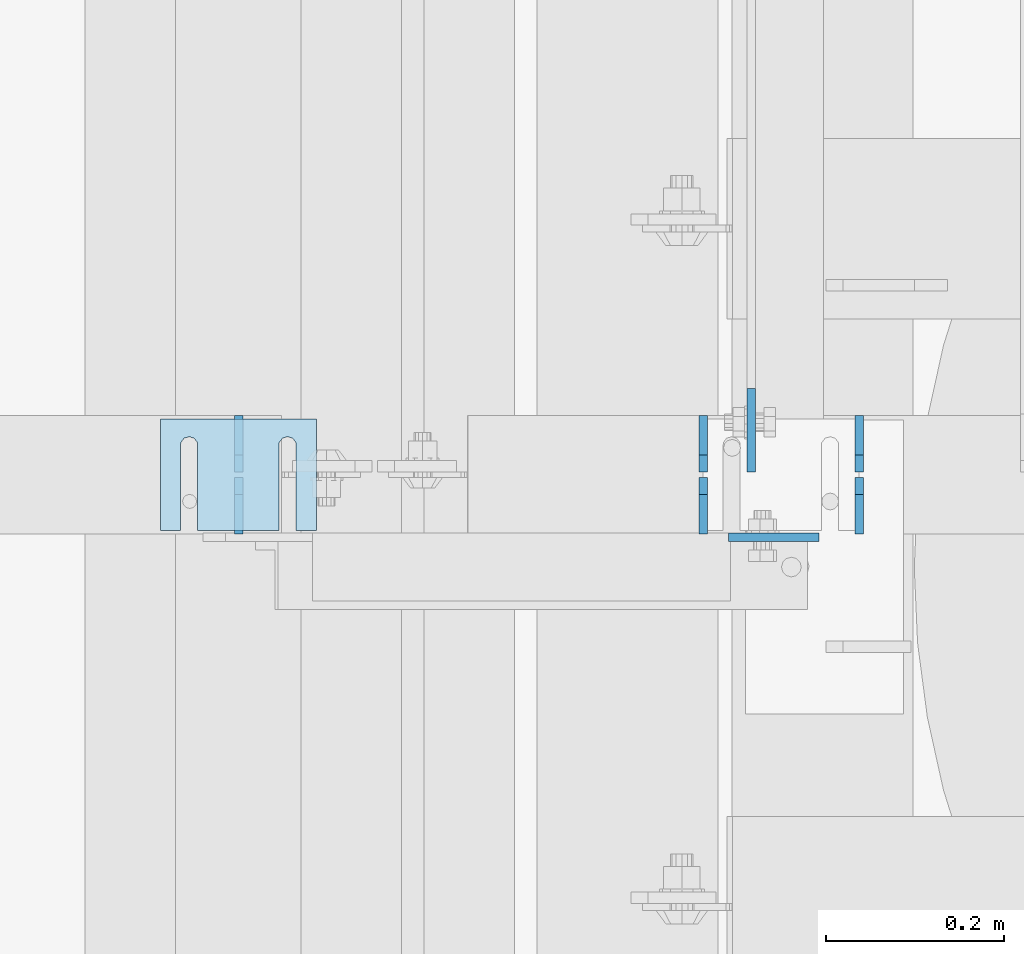
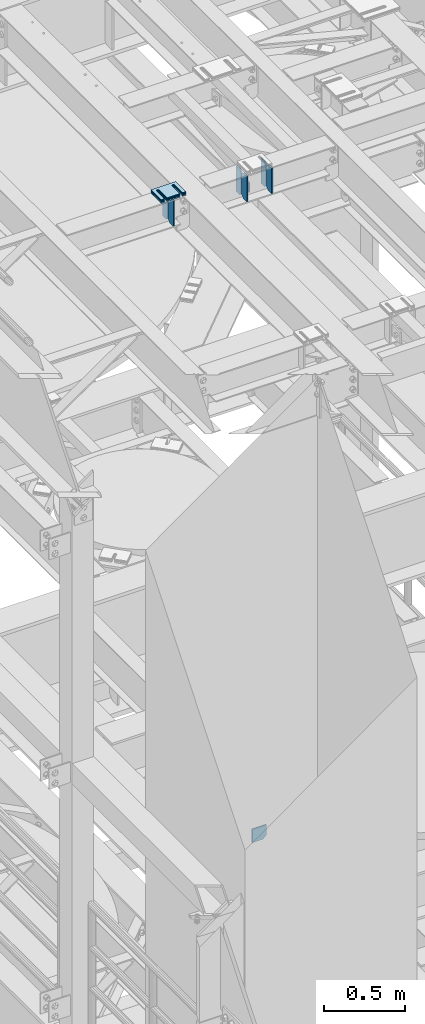
# One storey, part 1628 of 1876: 14 plates, 9 elements without a shape of their own.
"""IFC2X3 building model written with IfcOpenShell, lengths in millimetres."""

from ifc_helpers import new_model, si_unit, frame, origin_with_axes, place, context, subcontext, project, spatial, faceted_brep, material, type_object, element, aggregate, save


model = new_model("IFC2X3")

# Units and contexts
model_context = context("Model", 3, precision=1e-05, world=origin_with_axes())
body_context = subcontext(model_context, "Body", "Model", "MODEL_VIEW")
ifc_project = project(units=[si_unit("LENGTHUNIT", "METRE", prefix="MILLI"), si_unit("AREAUNIT", "SQUARE_METRE"), si_unit("VOLUMEUNIT", "CUBIC_METRE"), si_unit("MASSUNIT", "GRAM", prefix="KILO"), si_unit("TIMEUNIT", "SECOND"), si_unit("PLANEANGLEUNIT", "RADIAN"), si_unit("SOLIDANGLEUNIT", "STERADIAN"), si_unit("THERMODYNAMICTEMPERATUREUNIT", "DEGREE_CELSIUS"), si_unit("LUMINOUSINTENSITYUNIT", "LUMEN")], contexts=[model_context])

# Site, building, storey
site_placement = place(None, origin_with_axes())
site = spatial("IfcSite", under=ifc_project, at=site_placement, CompositionType="ELEMENT")
building_placement = place(site_placement, origin_with_axes())
building = spatial("IfcBuilding", under=site, at=building_placement, Name="Undefined", CompositionType="ELEMENT")
storey_placement = place(building_placement, origin_with_axes())
storey = spatial("IfcBuildingStorey", under=building, at=storey_placement, Name="Undefined", CompositionType="ELEMENT", Elevation=0.0)

# Assembly, plates
assembly_1_placement = place(storey_placement, origin_with_axes())
assembly_1 = element("IfcElementAssembly", 1, at=assembly_1_placement, inside=storey, Name="BEAM", AssemblyPlace="NOTDEFINED", PredefinedType="RIGID_FRAME")
ifc_material = material(Name="STEEL/A36")
plate_type_1 = type_object("IfcPlateType", PredefinedType="NOTDEFINED")
plate_1_placement = place(assembly_1_placement, frame((2343.14899226351, 5213.12356567383, 17784.7625), z_axis=(0.0, 0.0, 1.0), x_axis=(0.0, 1.0, 0.0)))
plate_1 = element("IfcPlate", 2, at=plate_1_placement, type_object=plate_type_1, material=ifc_material, Name="PLATE", context=body_context, shape_type="Brep", body=[
    faceted_brep([(0.0, -4.76249999999982, 0.0), (0.0, -4.76249999999982, 190.5), (0.0, 4.76249999999982, 190.5), (0.0, 4.76249999999982, 0.0), (44.4500007629395, -4.76249999999982, 190.5), (44.4500007629395, 4.76249999999982, 190.5), (63.5, -4.76249999999982, 171.450000762939), (63.5, 4.76249999999982, 171.450000762939), (63.5, -4.76249999999982, 19.0499992370605), (63.5, 4.76249999999982, 19.0499992370605), (44.4500007629395, -4.76249999999982, 0.0), (44.4500007629395, 4.76249999999982, 0.0)], [[[0, 1, 2, 3]], [[1, 4, 5, 2]], [[4, 6, 7, 5]], [[6, 8, 9, 7]], [[8, 10, 11, 9]], [[10, 0, 3, 11]], [[5, 7, 9, 11, 3, 2]], [[10, 8, 6, 4, 1, 0]]]),
])
plate_2_placement = place(assembly_1_placement, frame((2343.14899226351, 5282.97356567383, 17784.7625), z_axis=(0.0, 0.0, 1.0), x_axis=(0.0, 1.0, 0.0)))
plate_2 = element("IfcPlate", 3, at=plate_2_placement, type_object=plate_type_1, material=ifc_material, Name="PLATE", context=body_context, shape_type="Brep", body=[
    faceted_brep([(0.0, -4.76249999999982, 19.0499992370605), (0.0, -4.76249999999982, 171.450000762939), (0.0, 4.76249999999982, 171.450000762939), (0.0, 4.76249999999982, 19.0499992370605), (19.0499992370605, -4.76249999999982, 190.5), (19.0499992370605, 4.76249999999982, 190.5), (63.5, -4.76249999999982, 190.5), (63.5, 4.76249999999982, 190.5), (63.5, -4.76249999999982, 0.0), (63.5, 4.76249999999982, 0.0), (19.0499992370605, -4.76249999999982, 0.0), (19.0499992370605, 4.76249999999982, 0.0)], [[[0, 1, 2, 3]], [[1, 4, 5, 2]], [[4, 6, 7, 5]], [[6, 8, 9, 7]], [[8, 10, 11, 9]], [[10, 0, 3, 11]], [[5, 7, 9, 11, 3, 2]], [[10, 8, 6, 4, 1, 0]]]),
])
plate_3_placement = place(assembly_1_placement, frame((2167.75127412194, 5213.12356567383, 17784.7625), z_axis=(0.0, 0.0, 1.0), x_axis=(0.0, 1.0, 0.0)))
plate_3 = element("IfcPlate", 4, at=plate_3_placement, type_object=plate_type_1, material=ifc_material, Name="PLATE", context=body_context, shape_type="Brep", body=[
    faceted_brep([(0.0, -4.76249999999982, 0.0), (0.0, -4.76249999999982, 190.5), (0.0, 4.76249999999982, 190.5), (0.0, 4.76249999999982, 0.0), (44.4500007629395, -4.76249999999982, 190.5), (44.4500007629395, 4.76249999999982, 190.5), (63.5, -4.76249999999982, 171.450000762939), (63.5, 4.76249999999982, 171.450000762939), (63.5, -4.76249999999982, 19.0499992370605), (63.5, 4.76249999999982, 19.0499992370605), (44.4500007629395, -4.76249999999982, 0.0), (44.4500007629395, 4.76249999999982, 0.0)], [[[0, 1, 2, 3]], [[1, 4, 5, 2]], [[4, 6, 7, 5]], [[6, 8, 9, 7]], [[8, 10, 11, 9]], [[10, 0, 3, 11]], [[5, 7, 9, 11, 3, 2]], [[10, 8, 6, 4, 1, 0]]]),
])
plate_4_placement = place(assembly_1_placement, frame((2167.75127412194, 5282.97356567383, 17784.7625), z_axis=(0.0, 0.0, 1.0), x_axis=(0.0, 1.0, 0.0)))
plate_4 = element("IfcPlate", 5, at=plate_4_placement, type_object=plate_type_1, material=ifc_material, Name="PLATE", context=body_context, shape_type="Brep", body=[
    faceted_brep([(0.0, -4.76249999999982, 19.0499992370605), (0.0, -4.76249999999982, 171.450000762939), (0.0, 4.76249999999982, 171.450000762939), (0.0, 4.76249999999982, 19.0499992370605), (19.0499992370605, -4.76249999999982, 190.5), (19.0499992370605, 4.76249999999982, 190.5), (63.5, -4.76249999999982, 190.5), (63.5, 4.76249999999982, 190.5), (63.5, -4.76249999999982, 0.0), (63.5, 4.76249999999982, 0.0), (19.0499992370605, -4.76249999999982, 0.0), (19.0499992370605, 4.76249999999982, 0.0)], [[[0, 1, 2, 3]], [[1, 4, 5, 2]], [[4, 6, 7, 5]], [[6, 8, 9, 7]], [[8, 10, 11, 9]], [[10, 0, 3, 11]], [[5, 7, 9, 11, 3, 2]], [[10, 8, 6, 4, 1, 0]]]),
])

assembly_2_placement = place(storey_placement, origin_with_axes())
assembly_2 = element("IfcElementAssembly", 6, at=assembly_2_placement, inside=storey, Name="BEAM", AssemblyPlace="NOTDEFINED", PredefinedType="RIGID_FRAME")
plate_5_placement = place(assembly_2_placement, frame((1646.20416884927, 5213.12356567383, 17784.7625), z_axis=(0.0, 0.0, 1.0), x_axis=(0.0, 1.0, 0.0)))
plate_5 = element("IfcPlate", 7, at=plate_5_placement, type_object=plate_type_1, material=ifc_material, Name="PLATE", context=body_context, shape_type="Brep", body=[
    faceted_brep([(0.0, -4.76249999999982, 0.0), (0.0, -4.76249999999982, 190.5), (0.0, 4.76249999999982, 190.5), (0.0, 4.76249999999982, 0.0), (44.4500007629395, -4.76249999999982, 190.5), (44.4500007629395, 4.76249999999982, 190.5), (63.5, -4.76249999999982, 171.450000762939), (63.5, 4.76249999999982, 171.450000762939), (63.5, -4.76249999999982, 19.0499992370605), (63.5, 4.76249999999982, 19.0499992370605), (44.4500007629395, -4.76249999999982, 0.0), (44.4500007629395, 4.76249999999982, 0.0)], [[[0, 1, 2, 3]], [[1, 4, 5, 2]], [[4, 6, 7, 5]], [[6, 8, 9, 7]], [[8, 10, 11, 9]], [[10, 0, 3, 11]], [[5, 7, 9, 11, 3, 2]], [[10, 8, 6, 4, 1, 0]]]),
])
plate_6_placement = place(assembly_2_placement, frame((1646.20416884927, 5282.97356567383, 17784.7625), z_axis=(0.0, 0.0, 1.0), x_axis=(0.0, 1.0, 0.0)))
plate_6 = element("IfcPlate", 8, at=plate_6_placement, type_object=plate_type_1, material=ifc_material, Name="PLATE", context=body_context, shape_type="Brep", body=[
    faceted_brep([(0.0, -4.76249999999982, 19.0499992370605), (0.0, -4.76249999999982, 171.450000762939), (0.0, 4.76249999999982, 171.450000762939), (0.0, 4.76249999999982, 19.0499992370605), (19.0499992370605, -4.76249999999982, 190.5), (19.0499992370605, 4.76249999999982, 190.5), (63.5, -4.76249999999982, 190.5), (63.5, 4.76249999999982, 190.5), (63.5, -4.76249999999982, 0.0), (63.5, 4.76249999999982, 0.0), (19.0499992370605, -4.76249999999982, 0.0), (19.0499992370605, 4.76249999999982, 0.0)], [[[0, 1, 2, 3]], [[1, 4, 5, 2]], [[4, 6, 7, 5]], [[6, 8, 9, 7]], [[8, 10, 11, 9]], [[10, 0, 3, 11]], [[5, 7, 9, 11, 3, 2]], [[10, 8, 6, 4, 1, 0]]]),
])
aggregate(assembly_2, [plate_5, plate_6])

# Plate
plate_type_2 = type_object("IfcPlateType", PredefinedType="NOTDEFINED")
plate_7_placement = place(assembly_1_placement, frame((2222.11263366315, 5282.97350482595, 17866.0340203351), z_axis=(2.79999999293068e-08, 0.999999999998546, 1.70500000240281e-06), x_axis=(0.0, 1.70500000384316e-06, -0.999999999998546)))
plate_7 = element("IfcPlate", 9, at=plate_7_placement, type_object=plate_type_2, material=ifc_material, Name="PLATE", context=body_context, shape_type="Brep", body=[
    faceted_brep([(0.0, -4.76249999999982, 0.0), (0.000160036299348576, -4.76250000001437, 93.8535079955736), (0.000160036299348576, 4.76249999998527, 93.8535079955709), (0.0, 4.76249999999982, 0.0), (81.2716827393124, -4.76250000001482, 93.8533706664484), (81.2716827393124, 4.76249999998527, 93.8533706664448), (81.2715442022745, -4.76250000000164, 12.6999998092087), (81.2715442022745, 4.762499999998, 12.699999809206), (68.5715227128021, -4.76249999999982, -2.81943357549608e-11), (68.5715227128021, 4.76249999999982, -3.09228198602796e-11)], [[[0, 1, 2, 3]], [[1, 4, 5, 2]], [[4, 6, 7, 5]], [[6, 8, 9, 7]], [[8, 0, 3, 9]], [[5, 7, 9, 3, 2]], [[8, 6, 4, 1, 0]]]),
])

aggregate(assembly_1, [plate_1, plate_2, plate_3, plate_4, plate_7])

# Assembly, plate
assembly_3_placement = place(storey_placement, origin_with_axes())
assembly_3 = element("IfcElementAssembly", 10, at=assembly_3_placement, inside=storey, Name="BEAM", AssemblyPlace="NOTDEFINED", PredefinedType="RIGID_FRAME")
plate_type_3 = type_object("IfcPlateType", PredefinedType="NOTDEFINED")
plate_8_placement = place(assembly_3_placement, frame((2196.38446405378, 5209.4243484497, 13076.6976143139), z_axis=(1.0, 0.0, 0.0), x_axis=(0.0, 0.0, -1.0)))
plate_8 = element("IfcPlate", 11, at=plate_8_placement, type_object=plate_type_3, material=ifc_material, Name="PLATE", context=body_context, shape_type="Brep", body=[
    faceted_brep([(0.0, -4.76249999999982, 0.0), (0.0, -4.76249999999982, 101.521789550781), (0.0, 4.76249999999982, 101.521789550781), (0.0, 4.76249999999982, 0.0), (75.0726184844971, -4.76249999999982, 101.521789550781), (75.0726184844971, 4.76249999999982, 101.521789550781), (100.472618103027, -4.76249999999982, 76.121789932251), (100.472618103027, 4.76249999999982, 76.121789932251), (100.472618103027, -4.76249999999982, 0.0), (100.472618103027, 4.76249999999982, 0.0)], [[[0, 1, 2, 3]], [[1, 4, 5, 2]], [[4, 6, 7, 5]], [[6, 8, 9, 7]], [[8, 0, 3, 9]], [[5, 7, 9, 3, 2]], [[8, 6, 4, 1, 0]]]),
])
aggregate(assembly_3, [plate_8])

assembly_4_placement = place(storey_placement, origin_with_axes())
assembly_4 = element("IfcElementAssembly", 12, at=assembly_4_placement, inside=storey, Name="SHIM PLATE", AssemblyPlace="NOTDEFINED", PredefinedType="RIGID_FRAME")
plate_type_4 = type_object("IfcPlateType", PredefinedType="NOTDEFINED")
plate_9_placement = place(assembly_4_placement, frame((1733.54893551387, 5342.49779911298, 18009.3925), z_axis=(0.0, -1.0, 0.0), x_axis=(-1.0, 0.0, 0.0)))
plate_9 = element("IfcPlate", 13, at=plate_9_placement, type_object=plate_type_4, material=ifc_material, Name="SHIM PLATE", context=body_context, shape_type="Brep", body=[
    faceted_brep([(133.797984932592, -0.793499999999767, 125.39846801759), (133.799788185712, -0.793499999999767, 32.6385373098888), (133.799788185712, 0.793499999999767, 32.6385373098888), (133.797984932592, 0.793499999999767, 125.39846801759), (133.95251601168, -0.793499999999767, 26.6039999741197), (133.95251601168, 0.793499999999767, 26.6039999741197), (137.574395327988, -0.793499999999767, 21.7748223149583), (137.574395327988, 0.793499999999767, 21.7748223149583), (143.324785467194, -0.793499999999767, 19.9385271609622), (143.324785467194, 0.793499999999767, 19.9385271609622), (149.075176282759, -0.793499999999767, 21.7748201969102), (149.075176282759, 0.793499999999767, 21.7748201969102), (152.697057377795, -0.793499999999767, 26.6039965220207), (152.697057377795, 0.793499999999767, 26.6039965220207), (152.84978742646, -0.793499999999767, 32.6385338015343), (152.84978742646, 0.793499999999767, 32.6385338015343), (152.847984173361, -0.793499999999767, 125.398468017593), (152.847984173361, 0.793499999999767, 125.398468017593), (42.2236708188493, -0.793499999999767, 125.398468017582), (42.2236708188493, 0.793499999999767, 125.398468017582), (42.2254740719682, 0.793499999999767, 32.6385328059155), (42.2254740719682, -0.793499999999767, 32.6385328059155), (42.0727440233031, 0.793499999999767, 26.6039955264014), (42.0727440233031, -0.793499999999767, 26.6039955264014), (38.4508629282668, 0.793499999999767, 21.7748192012914), (38.4508629282668, -0.793499999999767, 21.7748192012914), (32.7004721127014, 0.793499999999767, 19.9385261653433), (32.7004721127014, -0.793499999999767, 19.9385261653433), (26.9500819734958, 0.793499999999767, 21.7748213193395), (26.9500819734958, -0.793499999999767, 21.7748213193395), (23.3282026571874, 0.793499999999767, 26.6039989785008), (23.3282026571874, -0.793499999999767, 26.6039989785008), (23.1754748312196, 0.793499999999767, 32.6385363142699), (23.1754748312196, -0.793499999999767, 32.6385363142699), (23.1736715780803, -0.793499999999767, 125.39846801758), (23.1736715780803, 0.793499999999767, 125.39846801758), (1.96488858819066e-05, 0.793499999999767, 125.398468017578), (1.96488858819066e-05, -0.793499999999767, 125.398468017578), (9.09494701772928e-13, -0.793499999999767, 0.0), (9.09494701772928e-13, 0.793499999999767, 0.0), (175.397720336914, -0.793499999999767, 7.27595761418343e-12), (175.397720336914, 0.793499999999767, 7.27595761418343e-12), (175.397735595691, -0.793499999999767, 125.398468017594), (175.397735595691, 0.793499999999767, 125.398468017594)], [[[0, 1, 2, 3]], [[4, 5, 2, 1]], [[6, 7, 5, 4]], [[8, 9, 7, 6]], [[10, 11, 9, 8]], [[12, 13, 11, 10]], [[14, 15, 13, 12]], [[16, 17, 15, 14]], [[18, 19, 20, 21]], [[21, 20, 22, 23]], [[23, 22, 24, 25]], [[25, 24, 26, 27]], [[27, 26, 28, 29]], [[29, 28, 30, 31]], [[31, 30, 32, 33]], [[34, 33, 32, 35]], [[36, 37, 34, 35]], [[38, 37, 36, 39]], [[40, 38, 39, 41]], [[42, 40, 41, 43]], [[12, 10, 8, 6, 4, 1, 0, 18, 21, 23, 25, 27, 29, 31, 33, 34, 37, 38, 40, 42, 16, 14]], [[19, 18, 0, 3]], [[43, 41, 39, 36, 35, 32, 30, 28, 26, 24, 22, 20, 19, 3, 2, 5, 7, 9, 11, 13, 15, 17]], [[42, 43, 17, 16]]]),
])
aggregate(assembly_4, [plate_9])

assembly_5_placement = place(storey_placement, origin_with_axes())
assembly_5 = element("IfcElementAssembly", 14, at=assembly_5_placement, inside=storey, Name="SHIM PLATE", AssemblyPlace="NOTDEFINED", PredefinedType="RIGID_FRAME")
plate_type_5 = type_object("IfcPlateType", PredefinedType="NOTDEFINED")
plate_10_placement = place(assembly_5_placement, frame((1733.54893551387, 5342.49779911306, 18007.0115), z_axis=(0.0, -1.0, 0.0), x_axis=(-1.0, 0.0, 0.0)))
plate_10 = element("IfcPlate", 15, at=plate_10_placement, type_object=plate_type_5, material=ifc_material, Name="SHIM PLATE", context=body_context, shape_type="Brep", body=[
    faceted_brep([(133.797984932592, -1.58750000000146, 125.39846801759), (133.799788185712, -1.58750000000146, 32.6385373098888), (133.799788185712, 1.58750000000146, 32.6385373098888), (133.797984932592, 1.58750000000146, 125.39846801759), (133.95251601168, -1.58750000000146, 26.6039999741197), (133.95251601168, 1.58750000000146, 26.6039999741197), (137.574395327988, -1.58750000000146, 21.7748223149583), (137.574395327988, 1.58750000000146, 21.7748223149583), (143.324785467194, -1.58750000000146, 19.9385271609622), (143.324785467194, 1.58750000000146, 19.9385271609622), (149.075176282759, -1.58750000000146, 21.7748201969102), (149.075176282759, 1.58750000000146, 21.7748201969102), (152.697057377795, -1.58750000000146, 26.6039965220207), (152.697057377795, 1.58750000000146, 26.6039965220207), (152.84978742646, -1.58750000000146, 32.6385338015343), (152.84978742646, 1.58750000000146, 32.6385338015343), (152.847984173361, -1.58750000000146, 125.398468017593), (152.847984173361, 1.58750000000146, 125.398468017593), (42.2236708188493, -1.58750000000146, 125.398468017582), (42.2236708188493, 1.58750000000146, 125.398468017582), (42.2254740719682, 1.58750000000146, 32.6385328059155), (42.2254740719682, -1.58750000000146, 32.6385328059155), (42.0727440233031, 1.58750000000146, 26.6039955264014), (42.0727440233031, -1.58750000000146, 26.6039955264014), (38.4508629282668, 1.58750000000146, 21.7748192012914), (38.4508629282668, -1.58750000000146, 21.7748192012914), (32.7004721127014, 1.58750000000146, 19.9385261653433), (32.7004721127014, -1.58750000000146, 19.9385261653433), (26.9500819734958, 1.58750000000146, 21.7748213193395), (26.9500819734958, -1.58750000000146, 21.7748213193395), (23.3282026571874, 1.58750000000146, 26.6039989785008), (23.3282026571874, -1.58750000000146, 26.6039989785008), (23.1754748312196, 1.58750000000146, 32.6385363142699), (23.1754748312196, -1.58750000000146, 32.6385363142699), (23.1736715780803, -1.58750000000146, 125.39846801758), (23.1736715780803, 1.58750000000146, 125.39846801758), (1.96491696442536e-05, 1.58750000000146, 125.398468017578), (1.96491696442536e-05, -1.58750000000146, 125.398468017578), (9.09494701772928e-13, -1.58750000000146, 4.54747350886464e-13), (9.09494701772928e-13, 1.58750000000146, 4.54747350886464e-13), (175.397720336914, -1.58750000000146, 7.27595761418343e-12), (175.397720336914, 1.58750000000146, 7.27595761418343e-12), (175.397735595691, -1.58750000000146, 125.398468017594), (175.397735595691, 1.58750000000146, 125.398468017594)], [[[0, 1, 2, 3]], [[4, 5, 2, 1]], [[6, 7, 5, 4]], [[8, 9, 7, 6]], [[10, 11, 9, 8]], [[12, 13, 11, 10]], [[14, 15, 13, 12]], [[16, 17, 15, 14]], [[18, 19, 20, 21]], [[21, 20, 22, 23]], [[23, 22, 24, 25]], [[25, 24, 26, 27]], [[27, 26, 28, 29]], [[29, 28, 30, 31]], [[31, 30, 32, 33]], [[34, 33, 32, 35]], [[36, 37, 34, 35]], [[38, 37, 36, 39]], [[40, 38, 39, 41]], [[42, 40, 41, 43]], [[12, 10, 8, 6, 4, 1, 0, 18, 21, 23, 25, 27, 29, 31, 33, 34, 37, 38, 40, 42, 16, 14]], [[19, 18, 0, 3]], [[43, 41, 39, 36, 35, 32, 30, 28, 26, 24, 22, 20, 19, 3, 2, 5, 7, 9, 11, 13, 15, 17]], [[42, 43, 17, 16]]]),
])
aggregate(assembly_5, [plate_10])

assembly_6_placement = place(storey_placement, origin_with_axes())
assembly_6 = element("IfcElementAssembly", 16, at=assembly_6_placement, inside=storey, Name="SHIM PLATE", AssemblyPlace="NOTDEFINED", PredefinedType="RIGID_FRAME")
plate_11_placement = place(assembly_6_placement, frame((1733.54893551387, 5342.49779911314, 18003.8365), z_axis=(0.0, -1.0, 0.0), x_axis=(-1.0, 0.0, 0.0)))
plate_11 = element("IfcPlate", 17, at=plate_11_placement, type_object=plate_type_5, material=ifc_material, Name="SHIM PLATE", context=body_context, shape_type="Brep", body=[
    faceted_brep([(133.797984932592, -1.58750000000146, 125.39846801759), (133.799788185712, -1.58750000000146, 32.6385373098888), (133.799788185712, 1.58750000000146, 32.6385373098888), (133.797984932592, 1.58750000000146, 125.39846801759), (133.95251601168, -1.58750000000146, 26.6039999741197), (133.95251601168, 1.58750000000146, 26.6039999741197), (137.574395327988, -1.58750000000146, 21.7748223149583), (137.574395327988, 1.58750000000146, 21.7748223149583), (143.324785467194, -1.58750000000146, 19.9385271609622), (143.324785467194, 1.58750000000146, 19.9385271609622), (149.075176282759, -1.58750000000146, 21.7748201969102), (149.075176282759, 1.58750000000146, 21.7748201969102), (152.697057377795, -1.58750000000146, 26.6039965220207), (152.697057377795, 1.58750000000146, 26.6039965220207), (152.84978742646, -1.58750000000146, 32.6385338015343), (152.84978742646, 1.58750000000146, 32.6385338015343), (152.847984173361, -1.58750000000146, 125.398468017593), (152.847984173361, 1.58750000000146, 125.398468017593), (42.2236708188493, -1.58750000000146, 125.398468017582), (42.2236708188493, 1.58750000000146, 125.398468017582), (42.2254740719682, 1.58750000000146, 32.6385328059155), (42.2254740719682, -1.58750000000146, 32.6385328059155), (42.0727440233031, 1.58750000000146, 26.6039955264014), (42.0727440233031, -1.58750000000146, 26.6039955264014), (38.4508629282668, 1.58750000000146, 21.7748192012914), (38.4508629282668, -1.58750000000146, 21.7748192012914), (32.7004721127014, 1.58750000000146, 19.9385261653433), (32.7004721127014, -1.58750000000146, 19.9385261653433), (26.9500819734958, 1.58750000000146, 21.7748213193395), (26.9500819734958, -1.58750000000146, 21.7748213193395), (23.3282026571874, 1.58750000000146, 26.6039989785008), (23.3282026571874, -1.58750000000146, 26.6039989785008), (23.1754748312196, 1.58750000000146, 32.6385363142699), (23.1754748312196, -1.58750000000146, 32.6385363142699), (23.1736715780803, -1.58750000000146, 125.39846801758), (23.1736715780803, 1.58750000000146, 125.39846801758), (1.96491696442536e-05, 1.58750000000146, 125.398468017578), (1.96491696442536e-05, -1.58750000000146, 125.398468017578), (9.09494701772928e-13, -1.58750000000146, 4.54747350886464e-13), (9.09494701772928e-13, 1.58750000000146, 4.54747350886464e-13), (175.397720336914, -1.58750000000146, 7.27595761418343e-12), (175.397720336914, 1.58750000000146, 7.27595761418343e-12), (175.397735595691, -1.58750000000146, 125.398468017594), (175.397735595691, 1.58750000000146, 125.398468017594)], [[[0, 1, 2, 3]], [[4, 5, 2, 1]], [[6, 7, 5, 4]], [[8, 9, 7, 6]], [[10, 11, 9, 8]], [[12, 13, 11, 10]], [[14, 15, 13, 12]], [[16, 17, 15, 14]], [[18, 19, 20, 21]], [[21, 20, 22, 23]], [[23, 22, 24, 25]], [[25, 24, 26, 27]], [[27, 26, 28, 29]], [[29, 28, 30, 31]], [[31, 30, 32, 33]], [[34, 33, 32, 35]], [[36, 37, 34, 35]], [[38, 37, 36, 39]], [[40, 38, 39, 41]], [[42, 40, 41, 43]], [[12, 10, 8, 6, 4, 1, 0, 18, 21, 23, 25, 27, 29, 31, 33, 34, 37, 38, 40, 42, 16, 14]], [[19, 18, 0, 3]], [[43, 41, 39, 36, 35, 32, 30, 28, 26, 24, 22, 20, 19, 3, 2, 5, 7, 9, 11, 13, 15, 17]], [[42, 43, 17, 16]]]),
])
aggregate(assembly_6, [plate_11])

assembly_7_placement = place(storey_placement, origin_with_axes())
assembly_7 = element("IfcElementAssembly", 18, at=assembly_7_placement, inside=storey, Name="SHIM PLATE", AssemblyPlace="NOTDEFINED", PredefinedType="RIGID_FRAME")
plate_type_6 = type_object("IfcPlateType", PredefinedType="NOTDEFINED")
plate_12_placement = place(assembly_7_placement, frame((1733.54893551387, 5342.49779911322, 17999.868), z_axis=(0.0, -1.0, 0.0), x_axis=(-1.0, 0.0, 0.0)))
plate_12 = element("IfcPlate", 19, at=plate_12_placement, type_object=plate_type_6, material=ifc_material, Name="SHIM PLATE", context=body_context, shape_type="Brep", body=[
    faceted_brep([(133.797984932592, -2.38100000000122, 125.39846801759), (133.799788185712, -2.38100000000122, 32.6385373098888), (133.799788185712, 2.38100000000122, 32.6385373098888), (133.797984932592, 2.38100000000122, 125.39846801759), (133.95251601168, -2.38100000000122, 26.6039999741197), (133.95251601168, 2.38100000000122, 26.6039999741197), (137.574395327988, -2.38100000000122, 21.7748223149583), (137.574395327988, 2.38100000000122, 21.7748223149583), (143.324785467194, -2.38100000000122, 19.9385271609622), (143.324785467194, 2.38100000000122, 19.9385271609622), (149.075176282759, -2.38100000000122, 21.7748201969102), (149.075176282759, 2.38100000000122, 21.7748201969102), (152.697057377795, -2.38100000000122, 26.6039965220207), (152.697057377795, 2.38100000000122, 26.6039965220207), (152.84978742646, -2.38100000000122, 32.6385338015343), (152.84978742646, 2.38100000000122, 32.6385338015343), (152.847984173361, -2.38100000000122, 125.398468017593), (152.847984173361, 2.38100000000122, 125.398468017593), (42.2236708188493, -2.38100000000122, 125.398468017582), (42.2236708188493, 2.38100000000122, 125.398468017582), (42.2254740719682, 2.38100000000122, 32.6385328059155), (42.2254740719682, -2.38100000000122, 32.6385328059155), (42.0727440233031, 2.38100000000122, 26.6039955264014), (42.0727440233031, -2.38100000000122, 26.6039955264014), (38.4508629282668, 2.38100000000122, 21.7748192012914), (38.4508629282668, -2.38100000000122, 21.7748192012914), (32.7004721127014, 2.38100000000122, 19.9385261653433), (32.7004721127014, -2.38100000000122, 19.9385261653433), (26.9500819734958, 2.38100000000122, 21.7748213193395), (26.9500819734958, -2.38100000000122, 21.7748213193395), (23.3282026571874, 2.38100000000122, 26.6039989785008), (23.3282026571874, -2.38100000000122, 26.6039989785008), (23.1754748312196, 2.38100000000122, 32.6385363142699), (23.1754748312196, -2.38100000000122, 32.6385363142699), (23.1736715780803, -2.38100000000122, 125.39846801758), (23.1736715780803, 2.38100000000122, 125.39846801758), (1.96494534066005e-05, 2.38100000000122, 125.398468017578), (1.96494534066005e-05, -2.38100000000122, 125.398468017578), (0.0, -2.38100000000122, 4.54747350886464e-13), (0.0, 2.38100000000122, 4.54747350886464e-13), (175.397720336914, -2.38100000000122, 7.27595761418343e-12), (175.397720336914, 2.38100000000122, 7.27595761418343e-12), (175.397735595691, -2.38100000000122, 125.398468017594), (175.397735595691, 2.38100000000122, 125.398468017594)], [[[0, 1, 2, 3]], [[4, 5, 2, 1]], [[6, 7, 5, 4]], [[8, 9, 7, 6]], [[10, 11, 9, 8]], [[12, 13, 11, 10]], [[14, 15, 13, 12]], [[16, 17, 15, 14]], [[18, 19, 20, 21]], [[21, 20, 22, 23]], [[23, 22, 24, 25]], [[25, 24, 26, 27]], [[27, 26, 28, 29]], [[29, 28, 30, 31]], [[31, 30, 32, 33]], [[34, 33, 32, 35]], [[36, 37, 34, 35]], [[38, 37, 36, 39]], [[40, 38, 39, 41]], [[42, 40, 41, 43]], [[12, 10, 8, 6, 4, 1, 0, 18, 21, 23, 25, 27, 29, 31, 33, 34, 37, 38, 40, 42, 16, 14]], [[19, 18, 0, 3]], [[43, 41, 39, 36, 35, 32, 30, 28, 26, 24, 22, 20, 19, 3, 2, 5, 7, 9, 11, 13, 15, 17]], [[42, 43, 17, 16]]]),
])
aggregate(assembly_7, [plate_12])

assembly_8_placement = place(storey_placement, origin_with_axes())
assembly_8 = element("IfcElementAssembly", 20, at=assembly_8_placement, inside=storey, Name="SHIM PLATE", AssemblyPlace="NOTDEFINED", PredefinedType="RIGID_FRAME")
plate_13_placement = place(assembly_8_placement, frame((1733.54893551387, 5342.4977991133, 17995.106), z_axis=(0.0, -1.0, 0.0), x_axis=(-1.0, 0.0, 0.0)))
plate_13 = element("IfcPlate", 21, at=plate_13_placement, type_object=plate_type_6, material=ifc_material, Name="SHIM PLATE", context=body_context, shape_type="Brep", body=[
    faceted_brep([(133.797984932592, -2.38100000000122, 125.39846801759), (133.799788185712, -2.38100000000122, 32.6385373098888), (133.799788185712, 2.38100000000122, 32.6385373098888), (133.797984932592, 2.38100000000122, 125.39846801759), (133.95251601168, -2.38100000000122, 26.6039999741197), (133.95251601168, 2.38100000000122, 26.6039999741197), (137.574395327988, -2.38100000000122, 21.7748223149583), (137.574395327988, 2.38100000000122, 21.7748223149583), (143.324785467194, -2.38100000000122, 19.9385271609622), (143.324785467194, 2.38100000000122, 19.9385271609622), (149.075176282759, -2.38100000000122, 21.7748201969102), (149.075176282759, 2.38100000000122, 21.7748201969102), (152.697057377795, -2.38100000000122, 26.6039965220207), (152.697057377795, 2.38100000000122, 26.6039965220207), (152.84978742646, -2.38100000000122, 32.6385338015343), (152.84978742646, 2.38100000000122, 32.6385338015343), (152.847984173361, -2.38100000000122, 125.398468017593), (152.847984173361, 2.38100000000122, 125.398468017593), (42.2236708188493, -2.38100000000122, 125.398468017582), (42.2236708188493, 2.38100000000122, 125.398468017582), (42.2254740719682, 2.38100000000122, 32.6385328059155), (42.2254740719682, -2.38100000000122, 32.6385328059155), (42.0727440233031, 2.38100000000122, 26.6039955264014), (42.0727440233031, -2.38100000000122, 26.6039955264014), (38.4508629282668, 2.38100000000122, 21.7748192012914), (38.4508629282668, -2.38100000000122, 21.7748192012914), (32.7004721127014, 2.38100000000122, 19.9385261653433), (32.7004721127014, -2.38100000000122, 19.9385261653433), (26.9500819734958, 2.38100000000122, 21.7748213193395), (26.9500819734958, -2.38100000000122, 21.7748213193395), (23.3282026571874, 2.38100000000122, 26.6039989785008), (23.3282026571874, -2.38100000000122, 26.6039989785008), (23.1754748312196, 2.38100000000122, 32.6385363142699), (23.1754748312196, -2.38100000000122, 32.6385363142699), (23.1736715780803, -2.38100000000122, 125.39846801758), (23.1736715780803, 2.38100000000122, 125.39846801758), (1.96494534066005e-05, 2.38100000000122, 125.398468017578), (1.96494534066005e-05, -2.38100000000122, 125.398468017578), (0.0, -2.38100000000122, 4.54747350886464e-13), (0.0, 2.38100000000122, 4.54747350886464e-13), (175.397720336914, -2.38100000000122, 7.27595761418343e-12), (175.397720336914, 2.38100000000122, 7.27595761418343e-12), (175.397735595691, -2.38100000000122, 125.398468017594), (175.397735595691, 2.38100000000122, 125.398468017594)], [[[0, 1, 2, 3]], [[4, 5, 2, 1]], [[6, 7, 5, 4]], [[8, 9, 7, 6]], [[10, 11, 9, 8]], [[12, 13, 11, 10]], [[14, 15, 13, 12]], [[16, 17, 15, 14]], [[18, 19, 20, 21]], [[21, 20, 22, 23]], [[23, 22, 24, 25]], [[25, 24, 26, 27]], [[27, 26, 28, 29]], [[29, 28, 30, 31]], [[31, 30, 32, 33]], [[34, 33, 32, 35]], [[36, 37, 34, 35]], [[38, 37, 36, 39]], [[40, 38, 39, 41]], [[42, 40, 41, 43]], [[12, 10, 8, 6, 4, 1, 0, 18, 21, 23, 25, 27, 29, 31, 33, 34, 37, 38, 40, 42, 16, 14]], [[19, 18, 0, 3]], [[43, 41, 39, 36, 35, 32, 30, 28, 26, 24, 22, 20, 19, 3, 2, 5, 7, 9, 11, 13, 15, 17]], [[42, 43, 17, 16]]]),
])
aggregate(assembly_8, [plate_13])

assembly_9_placement = place(storey_placement, origin_with_axes())
assembly_9 = element("IfcElementAssembly", 22, at=assembly_9_placement, inside=storey, Name="SHIM PLATE", AssemblyPlace="NOTDEFINED", PredefinedType="RIGID_FRAME")
plate_type_7 = type_object("IfcPlateType", PredefinedType="NOTDEFINED")
plate_14_placement = place(assembly_9_placement, frame((1733.54893551387, 5342.49779911338, 17987.9625), z_axis=(0.0, -1.0, 0.0), x_axis=(-1.0, 0.0, 0.0)))
plate_14 = element("IfcPlate", 23, at=plate_14_placement, type_object=plate_type_7, material=ifc_material, Name="SHIM PLATE", context=body_context, shape_type="Brep", body=[
    faceted_brep([(133.797984932592, -4.76250000000073, 125.39846801759), (133.799788185712, -4.76250000000073, 32.6385373098888), (133.799788185712, 4.76250000000073, 32.6385373098888), (133.797984932592, 4.76250000000073, 125.39846801759), (133.95251601168, -4.76250000000073, 26.6039999741197), (133.95251601168, 4.76250000000073, 26.6039999741197), (137.574395327988, -4.76250000000073, 21.7748223149583), (137.574395327988, 4.76250000000073, 21.7748223149583), (143.324785467194, -4.76250000000073, 19.9385271609622), (143.324785467194, 4.76250000000073, 19.9385271609622), (149.075176282759, -4.76250000000073, 21.7748201969102), (149.075176282759, 4.76250000000073, 21.7748201969102), (152.697057377795, -4.76250000000073, 26.6039965220207), (152.697057377795, 4.76250000000073, 26.6039965220207), (152.84978742646, -4.76250000000073, 32.6385338015343), (152.84978742646, 4.76250000000073, 32.6385338015343), (152.847984173361, -4.76250000000073, 125.398468017593), (152.847984173361, 4.76250000000073, 125.398468017593), (42.2236708188493, -4.76250000000073, 125.398468017582), (42.2236708188493, 4.76250000000073, 125.398468017582), (42.2254740719682, 4.76250000000073, 32.6385328059155), (42.2254740719682, -4.76250000000073, 32.6385328059155), (42.0727440233031, 4.76250000000073, 26.6039955264014), (42.0727440233031, -4.76250000000073, 26.6039955264014), (38.4508629282668, 4.76250000000073, 21.7748192012914), (38.4508629282668, -4.76250000000073, 21.7748192012914), (32.7004721127014, 4.76250000000073, 19.9385261653433), (32.7004721127014, -4.76250000000073, 19.9385261653433), (26.9500819734958, 4.76250000000073, 21.7748213193395), (26.9500819734958, -4.76250000000073, 21.7748213193395), (23.3282026571874, 4.76250000000073, 26.6039989785008), (23.3282026571874, -4.76250000000073, 26.6039989785008), (23.1754748312196, 4.76250000000073, 32.6385363142699), (23.1754748312196, -4.76250000000073, 32.6385363142699), (23.1736715780803, -4.76250000000073, 125.39846801758), (23.1736715780803, 4.76250000000073, 125.39846801758), (1.96497371689475e-05, 4.76250000000073, 125.398468017578), (1.96497371689475e-05, -4.76250000000073, 125.398468017578), (0.0, -4.76249999999982, 0.0), (0.0, 4.76249999999982, 0.0), (175.397720336914, -4.76250000000073, 7.27595761418343e-12), (175.397720336914, 4.76250000000073, 7.27595761418343e-12), (175.397735595691, -4.76250000000073, 125.398468017594), (175.397735595691, 4.76250000000073, 125.398468017594)], [[[0, 1, 2, 3]], [[4, 5, 2, 1]], [[6, 7, 5, 4]], [[8, 9, 7, 6]], [[10, 11, 9, 8]], [[12, 13, 11, 10]], [[14, 15, 13, 12]], [[16, 17, 15, 14]], [[18, 19, 20, 21]], [[21, 20, 22, 23]], [[23, 22, 24, 25]], [[25, 24, 26, 27]], [[27, 26, 28, 29]], [[29, 28, 30, 31]], [[31, 30, 32, 33]], [[34, 33, 32, 35]], [[36, 37, 34, 35]], [[38, 37, 36, 39]], [[40, 38, 39, 41]], [[42, 40, 41, 43]], [[12, 10, 8, 6, 4, 1, 0, 18, 21, 23, 25, 27, 29, 31, 33, 34, 37, 38, 40, 42, 16, 14]], [[19, 18, 0, 3]], [[43, 41, 39, 36, 35, 32, 30, 28, 26, 24, 22, 20, 19, 3, 2, 5, 7, 9, 11, 13, 15, 17]], [[42, 43, 17, 16]]]),
])
aggregate(assembly_9, [plate_14])

save(model, "model.ifc")
